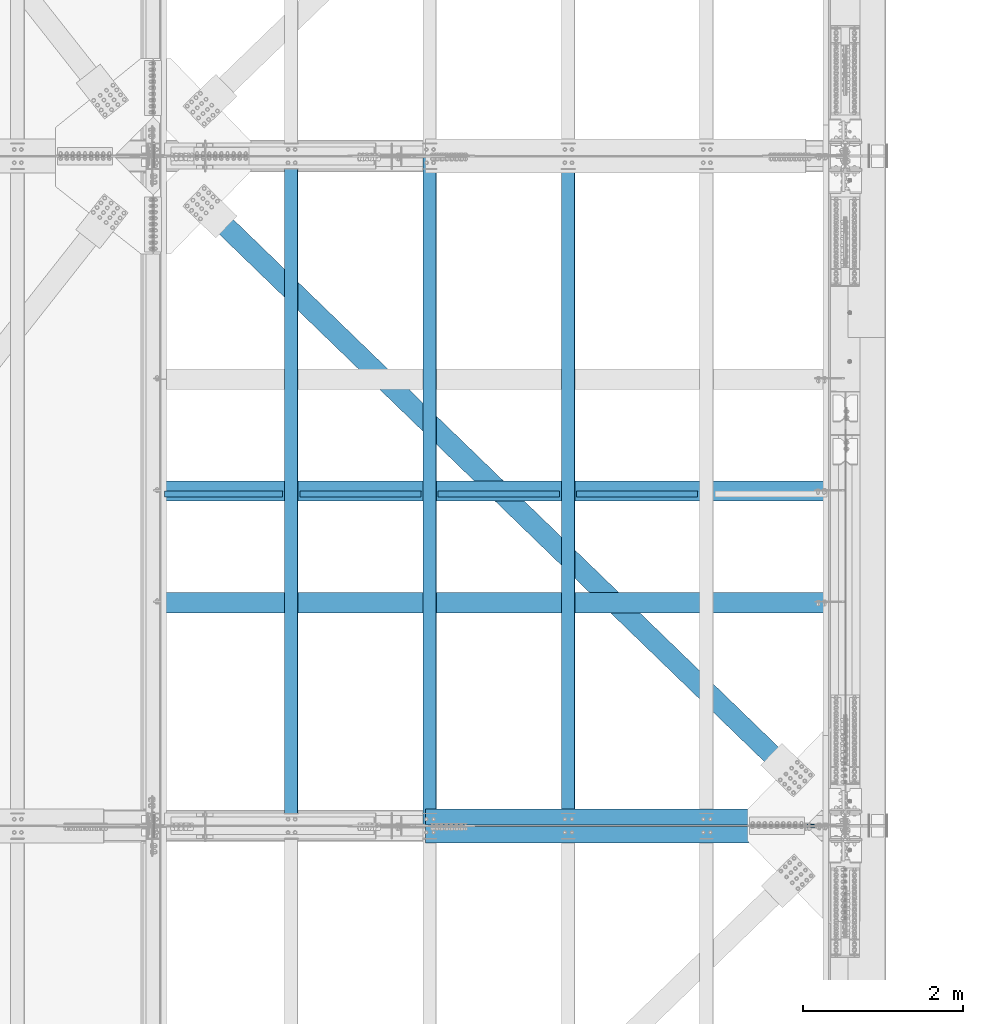
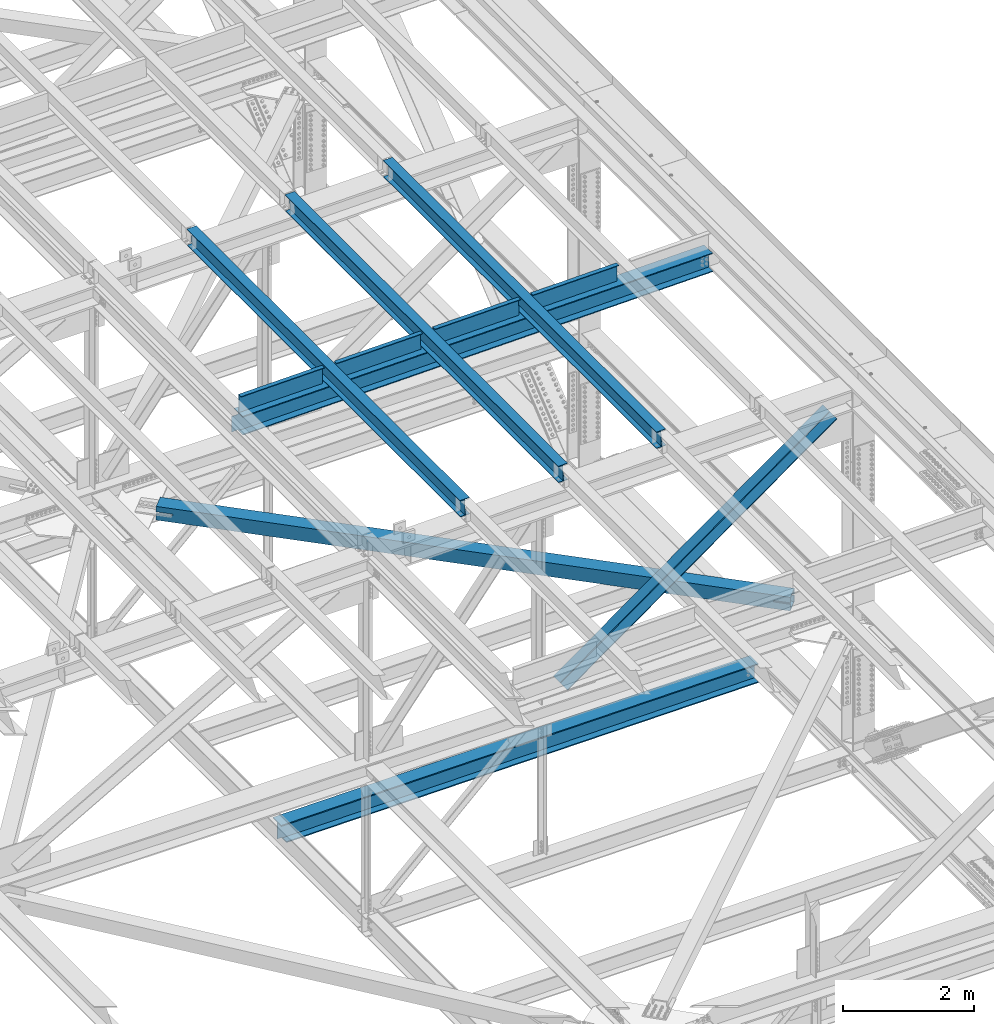
# One storey, part 1968 of 3843: 10 beams, 2 members, 12 elements without a shape of their own.
"""IFC2X3 building model written with IfcOpenShell, lengths in millimetres."""

from ifc_helpers import new_model, si_unit, frame, origin_with_axes, place, context, subcontext, project, spatial, faceted_brep, material, type_object, element, aggregate, save


model = new_model("IFC2X3")

# Units and contexts
model_context = context("Model", 3, precision=1e-05, world=origin_with_axes())
body_context = subcontext(model_context, "Body", "Model", "MODEL_VIEW")
ifc_project = project(units=[si_unit("LENGTHUNIT", "METRE", prefix="MILLI"), si_unit("AREAUNIT", "SQUARE_METRE"), si_unit("VOLUMEUNIT", "CUBIC_METRE"), si_unit("MASSUNIT", "GRAM", prefix="KILO"), si_unit("TIMEUNIT", "SECOND"), si_unit("PLANEANGLEUNIT", "RADIAN"), si_unit("SOLIDANGLEUNIT", "STERADIAN"), si_unit("THERMODYNAMICTEMPERATUREUNIT", "DEGREE_CELSIUS"), si_unit("LUMINOUSINTENSITYUNIT", "LUMEN")], contexts=[model_context])

# Site, building, storey
site_placement = place(None, origin_with_axes())
site = spatial("IfcSite", under=ifc_project, at=site_placement, CompositionType="ELEMENT")
building_placement = place(site_placement, origin_with_axes())
building = spatial("IfcBuilding", under=site, at=building_placement, Name="Undefined", CompositionType="ELEMENT")
storey_placement = place(building_placement, origin_with_axes())
storey = spatial("IfcBuildingStorey", under=building, at=storey_placement, Name="Undefined", CompositionType="ELEMENT", Elevation=0.0)

# Assembly, beam
assembly_1_placement = place(storey_placement, origin_with_axes())
assembly_1 = element("IfcElementAssembly", 1, at=assembly_1_placement, inside=storey, Name="BEAM", AssemblyPlace="NOTDEFINED", PredefinedType="RIGID_FRAME")
ifc_material_1 = material(Name="STEEL/A992")
beam_type_1 = type_object("IfcBeamType", Name="W12X26", PredefinedType="NOTDEFINED")
beam_1_placement = place(assembly_1_placement, frame((80463.909262375, 50558.6027872244, 46587.0318095099), z_axis=(-0.021152098138482, -0.000624861000040255, 0.999776074075125), x_axis=(0.0, 0.999999804686856, 0.000625000999804019)))
beam_1 = element("IfcBeam", 2, at=beam_1_placement, type_object=beam_type_1, material=ifc_material_1, Name="BEAM", ObjectType="W12X26", context=body_context, shape_type="Brep", body=[
    faceted_brep([(12.6989111619478, 82.5499999994208, -155.57500000031), (12.7048629657147, 82.549999999479, -146.050000000279), (8343.90649011454, 82.549999999901, -146.05000002039), (8343.90053831077, 82.5499999998428, -155.575000020421), (12.705912310128, 3.17499999904248, -146.050000000461), (8343.90753945895, 3.17499999946449, -146.050000020565), (12.888434292181, 3.17500000099244, 146.05000000041), (8344.09006144101, 3.17500000141445, 146.049999980307), (12.887384947775, 82.5500000014144, 146.050000000585), (8344.0890120966, 82.5500000018365, 146.049999980474), (12.8933367515347, 82.5500000014872, 155.575000000608), (8344.09496390036, 82.5500000019092, 155.574999980505), (12.8955193879083, -82.5499999994208, 155.575000000252), (8344.09714653673, -82.5499999989988, 155.574999980141), (12.8895675841413, -82.5499999994936, 146.050000000221), (8344.09119473297, -82.5499999990716, 146.049999980103), (12.888518239728, -3.17499999905704, 146.050000000396), (8344.09014538856, -3.17499999863503, 146.049999980285), (12.705996257675, -3.17500000097789, -146.050000000469), (8343.9076234065, -3.17500000055588, -146.050000020572), (12.7070456020883, -82.5500000014144, -146.050000000643), (8343.90867275091, -82.5500000009924, -146.050000020747), (12.7010937983214, -82.5500000014727, -155.575000000666), (8343.90272094715, -82.5500000010506, -155.575000020777)], [[[0, 1, 2, 3]], [[1, 4, 5, 2]], [[4, 6, 7, 5]], [[6, 8, 9, 7]], [[8, 10, 11, 9]], [[10, 12, 13, 11]], [[12, 14, 15, 13]], [[14, 16, 17, 15]], [[16, 18, 19, 17]], [[18, 20, 21, 19]], [[20, 22, 23, 21]], [[22, 0, 3, 23]], [[5, 7, 9, 11, 13, 15, 17, 19, 21, 23, 3, 2]], [[22, 20, 18, 16, 14, 12, 10, 8, 6, 4, 1, 0]]]),
])
aggregate(assembly_1, [beam_1])

assembly_2_placement = place(storey_placement, origin_with_axes())
assembly_2 = element("IfcElementAssembly", 3, at=assembly_2_placement, inside=storey, Name="BEAM", AssemblyPlace="NOTDEFINED", PredefinedType="RIGID_FRAME")
beam_2_placement = place(assembly_2_placement, frame((82191.1092624689, 50558.5989706009, 46619.4096360539), z_axis=(-0.021152098469087, -0.000649394000283794, 0.999776058433981), x_axis=(0.0, 0.999999789049521, 0.000649539000031958)))
beam_2 = element("IfcBeam", 4, at=beam_2_placement, type_object=beam_type_1, material=ifc_material_1, Name="BEAM", ObjectType="W12X26", context=body_context, shape_type="Brep", body=[
    faceted_brep([(12.6989111619478, 82.5499999994208, -155.57500000031), (12.7050539695047, 82.5500000006286, -146.050000000199), (8343.90681141782, 82.5500000011525, -146.050000024654), (8343.90062594179, 82.5500000011671, -155.575000024655), (12.7061445119398, 3.17500000017753, -146.050000000148), (8343.90790196026, 3.1750000007014, -146.050000024603), (12.895832443508, 3.17499999987194, 146.050000000083), (8344.09758989183, 3.17500000039581, 146.049999975621), (12.8947419010801, 82.5500000003231, 146.050000000025), (8344.0964993494, 82.5500000008469, 146.04999997557), (12.900927377108, 82.5500000003085, 155.575000000026), (8344.10268482543, 82.5500000008324, 155.574999975572), (12.9031957053667, -82.5500000006286, 155.575000000135), (8344.10495315369, -82.5500000001048, 155.574999975681), (12.8970102293388, -82.5500000006286, 146.050000000134), (8344.09876767766, -82.5500000001048, 146.049999975679), (12.8959196869109, -3.17500000017753, 146.050000000083), (8344.09767713523, -3.17499999965366, 146.049999975621), (12.7062317553282, -3.17499999985739, -146.050000000141), (8343.90798920366, -3.17499999933352, -146.050000024596), (12.7073222977706, -82.5500000003085, -146.05000000009), (8343.90907974609, -82.5499999997846, -146.050000024537), (12.7010937983214, -82.5500000014727, -155.575000000666), (8343.90289427006, -82.5499999997701, -155.575000024546)], [[[0, 1, 2, 3]], [[1, 4, 5, 2]], [[4, 6, 7, 5]], [[6, 8, 9, 7]], [[8, 10, 11, 9]], [[10, 12, 13, 11]], [[12, 14, 15, 13]], [[14, 16, 17, 15]], [[16, 18, 19, 17]], [[18, 20, 21, 19]], [[20, 22, 23, 21]], [[22, 0, 3, 23]], [[5, 7, 9, 11, 13, 15, 17, 19, 21, 23, 3, 2]], [[22, 20, 18, 16, 14, 12, 10, 8, 6, 4, 1, 0]]]),
])
aggregate(assembly_2, [beam_2])

assembly_3_placement = place(storey_placement, origin_with_axes())
assembly_3 = element("IfcElementAssembly", 5, at=assembly_3_placement, inside=storey, Name="BEAM", AssemblyPlace="NOTDEFINED", PredefinedType="RIGID_FRAME")
beam_3_placement = place(assembly_3_placement, frame((78736.709262375, 50558.6209151191, 46554.101074127), z_axis=(-0.021152097741724, -0.000508339000058186, 0.99977614011967), x_axis=(0.0, 0.999999870737765, 0.000508452999866475)))
beam_3 = element("IfcBeam", 6, at=beam_3_placement, type_object=beam_type_1, material=ifc_material_1, Name="BEAM", ObjectType="W12X26", context=body_context, shape_type="Brep", body=[
    faceted_brep([(12.6991634509395, 82.5499999998428, -155.574999999844), (12.7039557644093, 82.5499999995955, -146.050000000265), (8343.90503263363, 82.5499999998428, -146.050000011855), (8343.90019070176, 82.5499999997992, -155.575000011893), (12.7048094305574, 3.1749999991589, -146.050000000512), (8343.90588629978, 3.17499999940628, -146.050000012103), (12.8532953415051, 3.17500000087603, 146.050000000483), (8344.05437221073, 3.17500000112341, 146.0499999889), (12.8524416753571, 82.550000001298, 146.050000000723), (8344.05351854458, 82.5500000015454, 146.049999989147), (12.8572836072344, 82.5500000013417, 155.575000000761), (8344.05836047646, 82.5500000015891, 155.574999989178), (12.8590592328255, -82.5499999995372, 155.575000000252), (8344.06013610205, -82.5499999992899, 155.574999988661), (12.8542173009409, -82.54999999961, 146.050000000221), (8344.05529417018, -82.5499999993626, 146.049999988631), (12.8533636348002, -3.17499999917345, 146.050000000469), (8344.05444050402, -3.17499999892607, 146.049999988871), (12.7048777238451, -3.17500000087603, -146.050000000534), (8343.90595459306, -3.17500000061409, -146.050000012117), (12.7057313900004, -82.5500000013126, -146.050000000781), (8343.90680825922, -82.5500000010652, -146.050000012365), (12.700839471705, -82.5500000010798, -155.574999999444), (8343.90196632734, -82.5500000011089, -155.575000012395)], [[[0, 1, 2, 3]], [[1, 4, 5, 2]], [[4, 6, 7, 5]], [[6, 8, 9, 7]], [[8, 10, 11, 9]], [[10, 12, 13, 11]], [[12, 14, 15, 13]], [[14, 16, 17, 15]], [[16, 18, 19, 17]], [[18, 20, 21, 19]], [[20, 22, 23, 21]], [[22, 0, 3, 23]], [[5, 7, 9, 11, 13, 15, 17, 19, 21, 23, 3, 2]], [[22, 20, 18, 16, 14, 12, 10, 8, 6, 4, 1, 0]]]),
])
aggregate(assembly_3, [beam_3])

assembly_4_placement = place(storey_placement, origin_with_axes())
assembly_4 = element("IfcElementAssembly", 7, at=assembly_4_placement, inside=storey, Name="BENT_PLATE", AssemblyPlace="NOTDEFINED", PredefinedType="RIGID_FRAME")
ifc_material_2 = material(Name="STEEL/A36")
beam_type_2 = type_object("IfcBeamType", PredefinedType="NOTDEFINED")
beam_4_placement = place(assembly_4_placement, frame((77894.9341341534, 54732.2374999946, 46362.5904895629), z_axis=(-0.999843621600834, 0.0, -0.0176842399929445), x_axis=(-0.0176842399929427, 0.0, 0.999843621600834)))
beam_4 = element("IfcBeam", 8, at=beam_4_placement, type_object=beam_type_2, material=ifc_material_2, Name="BENT_PLATE", context=body_context, shape_type="Brep", body=[
    faceted_brep([(2.31375452131033e-09, -4.76249999999709, -736.599999997517), (-2.30647856369615e-09, -4.76249999999709, 736.599999997474), (-2.30647856369615e-09, 4.76249999999709, 736.599999997474), (2.31375452131033e-09, 4.76249999999709, -736.599999997517), (336.54999997931, 4.76249999995343, 736.599999998551), (336.549999983916, 4.76249999995343, -736.59999999647), (327.024999983958, -4.76250000004075, -736.599999996499), (327.024999979338, -4.76250000004075, 736.599999998522), (336.549999979303, -71.4375000011278, 736.599999998551), (336.549999983908, -71.4375000011278, -736.599999996455), (327.02499997933, -71.4375000011278, 736.599999998522), (327.024999983951, -71.4375000011278, -736.599999996499)], [[[0, 1, 2, 3]], [[3, 2, 4, 5]], [[1, 0, 6, 7]], [[5, 4, 8, 9]], [[4, 2, 1, 7, 10, 8]], [[7, 6, 11, 10]], [[6, 0, 3, 5, 9, 11]], [[10, 11, 9, 8]]]),
])
aggregate(assembly_4, [beam_4])

assembly_5_placement = place(storey_placement, origin_with_axes())
assembly_5 = element("IfcElementAssembly", 9, at=assembly_5_placement, inside=storey, Name="BENT_PLATE", AssemblyPlace="NOTDEFINED", PredefinedType="RIGID_FRAME")
beam_5_placement = place(assembly_5_placement, frame((79603.1323583162, 54732.2374999945, 46392.8034015666), z_axis=(-0.999843621600834, 0.0, -0.0176842399929445), x_axis=(-0.0176842399929427, 0.0, 0.999843621600834)))
beam_5 = element("IfcBeam", 10, at=beam_5_placement, type_object=beam_type_2, material=ifc_material_2, Name="BENT_PLATE", context=body_context, shape_type="Brep", body=[
    faceted_brep([(2.38651409745216e-09, -4.76249999999709, -755.649999997448), (-2.37923813983798e-09, -4.76249999999709, 755.649999997433), (-2.37923813983798e-09, 4.76249999999709, 755.649999997433), (2.38651409745216e-09, 4.76249999999709, -755.649999997448), (336.54999997891, 4.76249999995343, 755.649999998495), (336.549999983821, 4.76249999995343, -755.649999996385), (327.024999983856, -4.76250000004075, -755.649999996414), (327.024999978938, -4.76250000004075, 755.649999998466), (336.549999978997, -71.4375000010259, 755.649999998495), (336.549999983719, -71.4375000011714, -755.649999996371), (327.024999979025, -71.4375000010259, 755.649999998481), (327.024999983762, -71.4375000011714, -755.6499999964)], [[[0, 1, 2, 3]], [[3, 2, 4, 5]], [[1, 0, 6, 7]], [[5, 4, 8, 9]], [[4, 2, 1, 7, 10, 8]], [[7, 6, 11, 10]], [[6, 0, 3, 5, 9, 11]], [[10, 11, 9, 8]]]),
])
aggregate(assembly_5, [beam_5])

assembly_6_placement = place(storey_placement, origin_with_axes())
assembly_6 = element("IfcElementAssembly", 11, at=assembly_6_placement, inside=storey, Name="BENT_PLATE", AssemblyPlace="NOTDEFINED", PredefinedType="RIGID_FRAME")
beam_6_placement = place(assembly_6_placement, frame((81330.3776034704, 54732.2374999945, 46423.3531983421), z_axis=(-0.999843621600834, 0.0, -0.0176842399929445), x_axis=(-0.0176842399929427, 0.0, 0.999843621600834)))
beam_6 = element("IfcBeam", 12, at=beam_6_placement, type_object=beam_type_2, material=ifc_material_2, Name="BENT_PLATE", context=body_context, shape_type="Brep", body=[
    faceted_brep([(2.38651409745216e-09, -4.76249999999709, -755.649999997448), (-2.37923813983798e-09, -4.76249999999709, 755.649999997433), (-2.37923813983798e-09, 4.76249999999709, 755.649999997433), (2.38651409745216e-09, 4.76249999999709, -755.649999997448), (336.54999997891, 4.76249999995343, 755.649999998495), (336.549999983821, 4.76249999995343, -755.649999996385), (327.024999983856, -4.76250000004075, -755.649999996414), (327.024999978938, -4.76250000004075, 755.649999998466), (336.549999978997, -71.4375000010259, 755.649999998495), (336.549999983719, -71.4375000011714, -755.649999996371), (327.024999979025, -71.4375000010259, 755.649999998481), (327.024999983762, -71.4375000011714, -755.6499999964)], [[[0, 1, 2, 3]], [[3, 2, 4, 5]], [[1, 0, 6, 7]], [[5, 4, 8, 9]], [[4, 2, 1, 7, 10, 8]], [[7, 6, 11, 10]], [[6, 0, 3, 5, 9, 11]], [[10, 11, 9, 8]]]),
])
aggregate(assembly_6, [beam_6])

assembly_7_placement = place(storey_placement, origin_with_axes())
assembly_7 = element("IfcElementAssembly", 13, at=assembly_7_placement, inside=storey, Name="BENT_PLATE", AssemblyPlace="NOTDEFINED", PredefinedType="RIGID_FRAME")
beam_7_placement = place(assembly_7_placement, frame((83057.6228486247, 54732.2374999945, 46453.9029950985), z_axis=(-0.999843621600834, 0.0, -0.0176842399929445), x_axis=(-0.0176842399929427, 0.0, 0.999843621600834)))
beam_7 = element("IfcBeam", 14, at=beam_7_placement, type_object=beam_type_2, material=ifc_material_2, Name="BENT_PLATE", context=body_context, shape_type="Brep", body=[
    faceted_brep([(2.38651409745216e-09, -4.76249999999709, -755.649999997448), (-2.37923813983798e-09, -4.76249999999709, 755.649999997433), (-2.37923813983798e-09, 4.76249999999709, 755.649999997433), (2.38651409745216e-09, 4.76249999999709, -755.649999997448), (336.54999997891, 4.76249999995343, 755.649999998495), (336.549999983821, 4.76249999995343, -755.649999996385), (327.024999983856, -4.76250000004075, -755.649999996414), (327.024999978938, -4.76250000004075, 755.649999998466), (336.549999978997, -71.4375000010259, 755.649999998495), (336.549999983719, -71.4375000011714, -755.649999996371), (327.024999979025, -71.4375000010259, 755.649999998481), (327.024999983762, -71.4375000011714, -755.6499999964)], [[[0, 1, 2, 3]], [[3, 2, 4, 5]], [[1, 0, 6, 7]], [[5, 4, 8, 9]], [[4, 2, 1, 7, 10, 8]], [[7, 6, 11, 10]], [[6, 0, 3, 5, 9, 11]], [[10, 11, 9, 8]]]),
])
aggregate(assembly_7, [beam_7])

# Assembly, member
assembly_8_placement = place(storey_placement, origin_with_axes())
assembly_8 = element("IfcElementAssembly", 15, at=assembly_8_placement, inside=storey, Name="ANGLE", AssemblyPlace="NOTDEFINED", PredefinedType="RIGID_FRAME")
ifc_material_3 = material(Name="STEEL/A572-50")
member_type = type_object("IfcMemberType", Name="L8X8X1/2", PredefinedType="NOTDEFINED")
member_1_placement = place(assembly_8_placement, frame((85648.8000010528, 50669.825, 46330.0845331235), z_axis=(0.0, 1.0, 0.0), x_axis=(-0.813276002959696, 0.0, -0.581878116971158)))
member_1 = element("IfcMember", 16, at=member_1_placement, type_object=member_type, material=ifc_material_3, Name="ANGLE", ObjectType="L8X8X1/2", context=body_context, shape_type="Brep", body=[
    faceted_brep([(538.697347886729, 101.59999999761, -101.599999999999), (538.697347886729, 101.59999999761, 101.599999999999), (6370.32720949562, 101.599999973258, 101.599999999999), (6370.32720949562, 101.599999973258, -101.599999999999), (538.69734788686, 88.8999999976349, 101.599999999999), (6370.32720949574, 88.8999999732678, 101.599999999999), (538.69734788686, 88.8999999976349, -88.9000000000015), (6370.32720949574, 88.8999999732678, -88.9000000000015), (538.697347888796, -101.600000002118, -88.9000000000015), (6370.32720949767, -101.600000026478, -88.9000000000015), (538.697347888796, -101.600000002118, -101.599999999999), (6370.32720949767, -101.600000026478, -101.599999999999)], [[[0, 1, 2, 3]], [[1, 4, 5, 2]], [[4, 6, 7, 5]], [[6, 8, 9, 7]], [[8, 10, 11, 9]], [[10, 0, 3, 11]], [[5, 7, 9, 11, 3, 2]], [[10, 8, 6, 4, 1, 0]]]),
])
aggregate(assembly_8, [member_1])

assembly_9_placement = place(storey_placement, origin_with_axes())
assembly_9 = element("IfcElementAssembly", 17, at=assembly_9_placement, inside=storey, Name="ANGLE", AssemblyPlace="NOTDEFINED", PredefinedType="RIGID_FRAME")
member_2_placement = place(assembly_9_placement, frame((80060.7999999991, 50447.575, 42332.0138820875), z_axis=(0.0, -1.0, 0.0), x_axis=(0.813276002959693, 0.0, 0.581878116971162)))
member_2 = element("IfcMember", 18, at=member_2_placement, type_object=member_type, material=ifc_material_3, Name="ANGLE", ObjectType="L8X8X1/2", context=body_context, shape_type="Brep", body=[
    faceted_brep([(500.64891780114, 101.600000001965, -101.599999999999), (500.64891780114, 101.600000001965, 101.599999999999), (6332.27877941001, 101.600000026318, 101.599999999999), (6332.27877941001, 101.600000026318, -101.599999999999), (500.648917801023, 88.9000000019823, 101.599999999999), (6332.27877940988, 88.900000026335, 101.599999999999), (500.648917801023, 88.9000000019823, -88.9000000000015), (6332.27877940988, 88.900000026335, -88.9000000000015), (500.648917799073, -101.599999997763, -88.9000000000015), (6332.27877940796, -101.599999973418, -88.9000000000015), (500.648917799073, -101.599999997763, -101.599999999999), (6332.27877940796, -101.599999973418, -101.599999999999)], [[[0, 1, 2, 3]], [[1, 4, 5, 2]], [[4, 6, 7, 5]], [[6, 8, 9, 7]], [[8, 10, 11, 9]], [[10, 0, 3, 11]], [[5, 7, 9, 11, 3, 2]], [[10, 8, 6, 4, 1, 0]]]),
])
aggregate(assembly_9, [member_2])

# Assembly, beam
assembly_10_placement = place(storey_placement, origin_with_axes())
assembly_10 = element("IfcElementAssembly", 19, at=assembly_10_placement, inside=storey, AssemblyPlace="NOTDEFINED", PredefinedType="RIGID_FRAME")
ifc_material_4 = material()
beam_type_3 = type_object("IfcBeamType", Name="HSS10X10X3/4", PredefinedType="NOTDEFINED")
beam_8_placement = place(assembly_10_placement, frame((77012.8, 58915.3, 42246.55), z_axis=(0.695386222991622, 0.718636208991341, 0.0), x_axis=(0.718636212924518, -0.695386218926941, 0.0)))
beam_8 = element("IfcBeam", 20, at=beam_8_placement, type_object=beam_type_3, material=ifc_material_4, ObjectType="HSS10X10X3/4", context=body_context, shape_type="Brep", body=[
    faceted_brep([(1018.02056863531, 1.58800048788544, 126.999999994441), (1018.02056863551, 1.58800048788544, 107.949999994438), (1270.43308512671, 1.58800048788544, 107.94999999307), (1270.43308594835, 1.58800048788544, 126.999999993073), (1275.9006748126, 0.500429279600212, 107.949999993041), (1275.90067563424, 0.500429279600212, 126.999999993044), (1280.53587353265, -2.59671148764028, 107.949999993012), (1280.53587435429, -2.59671148764028, 126.999999993015), (1283.63301429989, -7.23191020768718, 107.949999992998), (1283.63301512154, -7.23191020768718, 126.999999993001), (1270.43308594835, -26.9869995121117, 126.999999993073), (1270.43308512671, -26.9869995121117, 107.94999999307), (1018.02056863551, -26.9869995121117, 107.949999994438), (1018.02056863531, -26.9869995121117, 126.999999994441), (1275.90067563424, -25.8994283038264, 126.999999993044), (1275.9006748126, -25.8994283038264, 107.949999993041), (1280.53587435429, -22.8022875365859, 126.999999993015), (1280.53587353265, -22.8022875365859, 107.949999993012), (1283.63301512154, -18.167088816539, 126.999999993001), (1283.63301429989, -18.167088816539, 107.949999992998), (1284.72058632981, -12.6994991306419, 126.999999992986), (1284.72058550817, -12.6994991306419, 107.949999992998), (1018.02056863772, 1.58800048788544, -107.950000005483), (1018.02056863792, 1.58800048788544, -127.000000005472), (1270.43307499317, 1.58800048788544, -127.000000006854), (1270.43307581481, 1.58800048788544, -107.950000006866), (1275.90066467908, 0.500429279600212, -127.000000006883), (1275.90066550071, 0.500429279600212, -107.95000000688), (1280.53586339912, -2.59671148764028, -127.000000006912), (1280.53586422076, -2.59671148764028, -107.950000006909), (1283.63300416635, -7.23191020768718, -127.000000006927), (1283.633004988, -7.23191020768718, -107.950000006924), (1270.43307581481, -26.9869995121117, -107.950000006866), (1270.43307499317, -26.9869995121117, -127.000000006854), (1018.02056863792, -26.9869995121117, -127.000000005472), (1018.02056863772, -26.9869995121117, -107.950000005483), (1275.90066550071, -25.8994283038264, -107.95000000688), (1275.90066467908, -25.8994283038264, -127.000000006883), (1280.53586422076, -22.8022875365859, -107.950000006909), (1280.53586339912, -22.8022875365859, -127.000000006912), (1283.633004988, -18.167088816539, -107.950000006924), (1283.63300416635, -18.167088816539, -127.000000006927), (1284.72057619627, -12.6994991306419, -107.950000006938), (1284.72057537464, -12.6994991306419, -127.000000006927), (1018.02056851298, 107.949999999997, 107.950000003533), (1018.02056851263, 107.949999999997, -107.949999995799), (10985.3110826047, 107.949999999997, -107.950000059674), (10985.3110826025, 107.949999999997, 107.949999940247), (1018.02056851258, 127.0, -126.999999995736), (10985.3110826049, 127.0, -127.000000059677), (10985.3110826049, 1.5869997032205, -127.000000059677), (10732.8985700496, 1.5869997032205, -127.000000058295), (10727.4309803637, 0.499428494935273, -127.000000058266), (10722.7957816437, -2.59771227230522, -127.000000058237), (10719.6986408764, -7.23291099235212, -127.000000058237), (10718.6110696682, -12.7004999153069, -127.000000058222), (10719.6986408764, -18.168089601204, -127.000000058237), (10722.7957816437, -22.8032883212509, -127.000000058237), (10727.4309803637, -25.9004290884914, -127.000000058266), (10732.8985700496, -26.9880002967766, -127.000000058295), (10985.3110826049, -26.9880002967766, -127.000000059677), (10985.3110826049, -127.0, -127.000000059677), (1018.02056851258, -127.0, -126.999999995736), (10732.8985701572, 1.5869997032205, -107.950000058307), (10985.3110826047, 1.5869997032205, -107.950000059674), (10727.4309804713, 0.499428494935273, -107.950000058278), (10722.7957817513, -2.59771227230522, -107.950000058248), (10719.6986409841, -7.23291099235212, -107.950000058234), (10718.6110697758, -12.7004999153069, -107.950000058234), (10719.6986409841, -18.168089601204, -107.950000058234), (10722.7957817513, -22.8032883212509, -107.950000058248), (10727.4309804713, -25.9004290884914, -107.950000058278), (10732.8985701572, -26.9880002967766, -107.950000058307), (10985.3110826047, -26.9880002967766, -107.950000059674), (1018.02056851263, -107.949999999997, -107.949999995799), (1018.02056851298, -107.949999999997, 107.950000003533), (10985.3110826025, -107.949999999997, 107.949999940247), (10985.3110826047, -107.949999999997, -107.950000059674), (10727.4309817989, 0.499428494935273, 126.999999941647), (10727.4309816912, 0.499428494935273, 107.949999941658), (10732.8985713771, 1.5869997032205, 107.949999941629), (10732.8985714847, 1.5869997032205, 126.999999941618), (10722.7957830788, -2.59771227230522, 126.999999941676), (10722.7957829712, -2.59771227230522, 107.949999941673), (10719.6986423116, -7.23291099235212, 126.99999994169), (10719.698642204, -7.23291099235212, 107.949999941688), (10718.6110711033, -12.7004999153069, 126.999999941705), (10718.6110709957, -12.7004999153069, 107.949999941702), (10719.6986423116, -18.168089601204, 126.99999994169), (10719.698642204, -18.168089601204, 107.949999941688), (10722.7957830788, -22.8032883212509, 126.999999941676), (10722.7957829712, -22.8032883212509, 107.949999941673), (10727.4309817989, -25.9004290884914, 126.999999941647), (10727.4309816912, -25.9004290884914, 107.949999941658), (10732.8985714847, -26.9880002967766, 126.999999941618), (10732.8985713771, -26.9880002967766, 107.949999941629), (10985.3110826023, -26.9880002967766, 126.99999994025), (10985.3110826025, -26.9880002967766, 107.949999940247), (10985.3110826023, -127.0, 126.99999994025), (1018.02056851302, -127.0, 127.000000003467), (10985.3110826025, 1.5869997032205, 107.949999940247), (10985.3110826023, 1.5869997032205, 126.99999994025), (10985.3110826023, 127.0, 126.99999994025), (1018.02056851302, 127.0, 127.000000003467)], [[[0, 1, 2, 3]], [[3, 2, 4, 5]], [[5, 4, 6, 7]], [[7, 6, 8, 9]], [[10, 11, 12, 13]], [[14, 15, 11, 10]], [[16, 17, 15, 14]], [[18, 19, 17, 16]], [[20, 21, 19, 18]], [[9, 8, 21, 20]], [[22, 23, 24, 25]], [[25, 24, 26, 27]], [[27, 26, 28, 29]], [[29, 28, 30, 31]], [[32, 33, 34, 35]], [[36, 37, 33, 32]], [[38, 39, 37, 36]], [[40, 41, 39, 38]], [[42, 43, 41, 40]], [[31, 30, 43, 42]], [[44, 45, 46, 47]], [[28, 26, 24, 23, 48, 49, 50, 51, 52, 53, 54, 55, 56, 57, 58, 59, 60, 61, 62, 34, 33, 37, 39, 41, 43, 30]], [[63, 51, 50, 64]], [[65, 52, 51, 63]], [[66, 53, 52, 65]], [[67, 54, 53, 66]], [[68, 55, 54, 67]], [[69, 56, 55, 68]], [[70, 57, 56, 69]], [[71, 58, 57, 70]], [[72, 59, 58, 71]], [[59, 72, 73, 60]], [[74, 75, 76, 77]], [[78, 79, 80, 81]], [[82, 83, 79, 78]], [[84, 85, 83, 82]], [[86, 87, 85, 84]], [[88, 89, 87, 86]], [[90, 91, 89, 88]], [[92, 93, 91, 90]], [[94, 95, 93, 92]], [[95, 94, 96, 97]], [[60, 73, 77, 76, 97, 96, 98, 61]], [[99, 62, 61, 98]], [[75, 74, 35, 34, 62, 99, 13, 12]], [[6, 4, 2, 1, 44, 47, 100, 80, 79, 83, 85, 87, 89, 91, 93, 95, 97, 76, 75, 12, 11, 15, 17, 19, 21, 8]], [[81, 80, 100, 101]], [[47, 46, 64, 50, 49, 102, 101, 100]], [[48, 103, 102, 49]], [[16, 14, 10, 13, 99, 98, 96, 94, 92, 90, 88, 86, 84, 82, 78, 81, 101, 102, 103, 0, 3, 5, 7, 9, 20, 18]], [[103, 48, 23, 22, 45, 44, 1, 0]], [[38, 36, 32, 35, 74, 77, 73, 72, 71, 70, 69, 68, 67, 66, 65, 63, 64, 46, 45, 22, 25, 27, 29, 31, 42, 40]]]),
])
aggregate(assembly_10, [beam_8])

assembly_11_placement = place(storey_placement, origin_with_axes())
assembly_11 = element("IfcElementAssembly", 21, at=assembly_11_placement, inside=storey, Name="BEAM", AssemblyPlace="NOTDEFINED", PredefinedType="RIGID_FRAME")
beam_type_4 = type_object("IfcBeamType", Name="W14X61", PredefinedType="NOTDEFINED")
beam_9_placement = place(assembly_11_placement, frame((77012.799999465, 54737.0, 46170.5955782741), z_axis=(-0.0176842399929427, 0.0, 0.999843621600834), x_axis=(0.999843621600834, 0.0, 0.0176842399929401)))
beam_9 = element("IfcBeam", 22, at=beam_9_placement, type_object=beam_type_4, material=ifc_material_1, Name="BEAM", ObjectType="W14X61", context=body_context, shape_type="Brep", body=[
    faceted_brep([(15.703996780474, -4.76249999999709, -144.462500014764), (15.703996780474, 4.76249999999709, -144.462500014764), (129.442434533223, 4.76249999999709, -144.462500014415), (129.442434533223, -4.76249999999709, -144.462500014415), (134.302514051233, 4.76249999999709, -145.429229936963), (134.302514051233, -4.76249999999709, -145.429229936963), (138.42269051935, 4.76249999999709, -148.182243837407), (138.42269051935, -4.76249999999709, -148.182243837407), (141.175704419802, 4.76249999999709, -152.30242030551), (141.175704419802, -4.76249999999709, -152.30242030551), (142.142434342401, -4.76249999999709, -157.162499823506), (142.142434342401, 4.76249999999709, -157.162499823506), (142.142434342401, 4.76249999999709, -160.337499999019), (142.142434342401, 127.0, -160.337499999019), (142.142434342459, 127.0, -176.212499998961), (142.142434342459, -127.0, -176.212499998961), (142.142434342401, -127.0, -160.337499999019), (142.142434342401, -4.76249999999709, -160.337499999019), (8418.30025665686, -127.0, 160.337500025853), (8418.30025665686, -127.0, 176.212500025795), (142.142434341309, -127.0, 176.212499999849), (142.142434341382, -127.0, 160.3374999999), (8418.30025665686, 127.0, 176.212500025795), (142.142434341309, 127.0, 176.212499999849), (8418.30025665686, 127.0, 160.337500025853), (142.142434341382, 127.0, 160.3374999999), (8418.30025665686, 4.76249999999709, 160.337500025853), (142.142434341382, 4.76249999999709, 160.3374999999), (129.442434532291, -4.76249999999709, 144.462499982663), (129.442434532291, 4.76249999999709, 144.462499982663), (20.8142149481137, 4.76249999999709, 144.462499982321), (20.8142149481137, -4.76249999999709, 144.462499982321), (134.302514050272, -4.76249999999709, 145.429229905261), (134.302514050272, 4.76249999999709, 145.429229905261), (138.42269051839, -4.76249999999709, 148.182243805721), (138.42269051839, 4.76249999999709, 148.182243805721), (141.175704418827, -4.76249999999709, 152.302420273838), (141.175704418827, 4.76249999999709, 152.302420273838), (142.142434341382, -4.76249999999709, 157.162499791848), (142.142434341382, 4.76249999999709, 157.162499791848), (142.142434341382, -4.76249999999709, 160.3374999999), (8418.30025665686, -4.76249999999709, 160.337500025853), (8418.30025665685, 4.76249999999709, -160.337499973066), (8418.30025665685, -4.76249999999709, -160.337499973066), (8418.30025665685, -127.0, -160.337499973066), (8418.30025665686, -127.0, -176.212499973015), (8418.30025665686, 127.0, -176.212499973015), (8418.30025665685, 127.0, -160.337499973066), (16.6337421439675, 4.76249999999709, -91.8959225554063), (20.7117278863152, 4.76249999999709, 138.668016584197)], [[[0, 1, 2, 3]], [[3, 2, 4, 5]], [[5, 4, 6, 7]], [[7, 6, 8, 9]], [[10, 11, 12, 13, 14, 15, 16, 17]], [[9, 8, 11, 10]], [[18, 19, 20, 21]], [[19, 22, 23, 20]], [[22, 24, 25, 23]], [[24, 26, 27, 25]], [[28, 29, 30, 31]], [[32, 33, 29, 28]], [[34, 35, 33, 32]], [[36, 37, 35, 34]], [[38, 39, 37, 36]], [[20, 23, 25, 27, 39, 38, 40, 21]], [[41, 18, 21, 40]], [[42, 26, 24, 22, 19, 18, 41, 43, 44, 45, 46, 47]], [[44, 43, 17, 16]], [[45, 44, 16, 15]], [[46, 45, 15, 14]], [[47, 46, 14, 13]], [[42, 47, 13, 12]], [[6, 4, 2, 1, 48, 49, 30, 29, 33, 35, 37, 39, 27, 26, 42, 12, 11, 8]], [[31, 30, 49, 48, 1, 0]], [[43, 41, 40, 38, 36, 34, 32, 28, 31, 0, 3, 5, 7, 9, 10, 17]]]),
])
aggregate(assembly_11, [beam_9])

assembly_12_placement = place(storey_placement, origin_with_axes())
assembly_12 = element("IfcElementAssembly", 23, at=assembly_12_placement, inside=storey, Name="BEAM", AssemblyPlace="NOTDEFINED", PredefinedType="RIGID_FRAME")
beam_type_5 = type_object("IfcBeamType", Name="W14X68", PredefinedType="NOTDEFINED")
beam_10_placement = place(assembly_12_placement, frame((77011.2864009236, 53343.770316, 39446.1935573013), z_axis=(-0.00851308500030426, 0.0, 0.99996376303533), x_axis=(0.99996376303533, 0.0, 0.00851308500030053)))
beam_10 = element("IfcBeam", 24, at=beam_10_placement, type_object=beam_type_5, material=ifc_material_1, Name="BEAM", ObjectType="W14X68", context=body_context, shape_type="Brep", body=[
    faceted_brep([(18.5272118865687, -5.55625000000146, -146.049999995361), (18.5272118865687, 5.55625000000146, -146.049999995361), (94.4569118349318, 5.55625000000146, -146.049999997376), (94.4569118349318, -5.55625000000146, -146.049999997376), (99.3169913531019, 5.55625000000146, -147.016729919989), (99.3169913531019, -5.55625000000146, -147.016729919989), (103.437167821379, 5.55625000000146, -149.769743820485), (103.437167821379, -5.55625000000146, -149.769743820485), (106.190181721948, 5.55625000000146, -153.889920288661), (106.190181721948, -5.55625000000146, -153.889920288661), (107.15691164459, 5.55625000000146, -158.749999999636), (107.15691164459, -5.55625000000146, -158.749999999636), (107.156911644604, -127.0, -158.749999806714), (107.15691164459, 127.0, -158.749999999636), (107.15691164443, 127.0, -177.799999999566), (107.15691164443, -127.0, -177.799999999566), (21.1220422441984, 5.55625000000146, 158.750000000357), (21.1220422441984, 127.0, 158.750000000357), (8423.27024961499, 127.0, 158.749999998683), (8423.27024961499, 5.55625000000146, 158.749999998683), (21.2842194564, 127.0, 177.800000000396), (8423.43242682719, 127.0, 177.79999999873), (21.2842194564, -127.0, 177.800000000396), (8423.43242682719, -127.0, 177.79999999873), (21.1220422441984, -127.0, 158.750000000357), (8423.27024961499, -127.0, 158.749999998683), (21.1220422441984, -5.55625000000146, 158.750000000357), (8423.27024961499, -5.55625000000146, 158.749999998683), (8420.56731019873, 5.55625000000146, -158.750000015585), (8420.56731019873, -5.55625000000146, -158.750000015585), (8420.56731019873, -127.0, -158.750000015585), (8420.40513005269, -127.0, -177.800000015523), (8420.40513005269, 127.0, -177.800000015523), (8420.56731019873, 127.0, -158.750000015585), (18.8909659154015, 5.55625000000146, -103.322733934961), (20.854036143035, 5.55625000000146, 127.268904981516)], [[[0, 1, 2, 3]], [[3, 2, 4, 5]], [[5, 4, 6, 7]], [[7, 6, 8, 9]], [[9, 8, 10, 11]], [[12, 11, 10, 13, 14, 15]], [[16, 17, 18, 19]], [[17, 20, 21, 18]], [[20, 22, 23, 21]], [[22, 24, 25, 23]], [[24, 26, 27, 25]], [[28, 19, 18, 21, 23, 25, 27, 29, 30, 31, 32, 33]], [[31, 30, 12, 15]], [[32, 31, 15, 14]], [[33, 32, 14, 13]], [[28, 33, 13, 10]], [[6, 4, 2, 1, 34, 35, 16, 19, 28, 10, 8]], [[26, 24, 22, 20, 17, 16, 35, 34, 1, 0]], [[29, 27, 26, 0, 3, 5, 7, 9, 11]], [[30, 29, 11, 12]]]),
])
aggregate(assembly_12, [beam_10])

save(model, "model.ifc")
